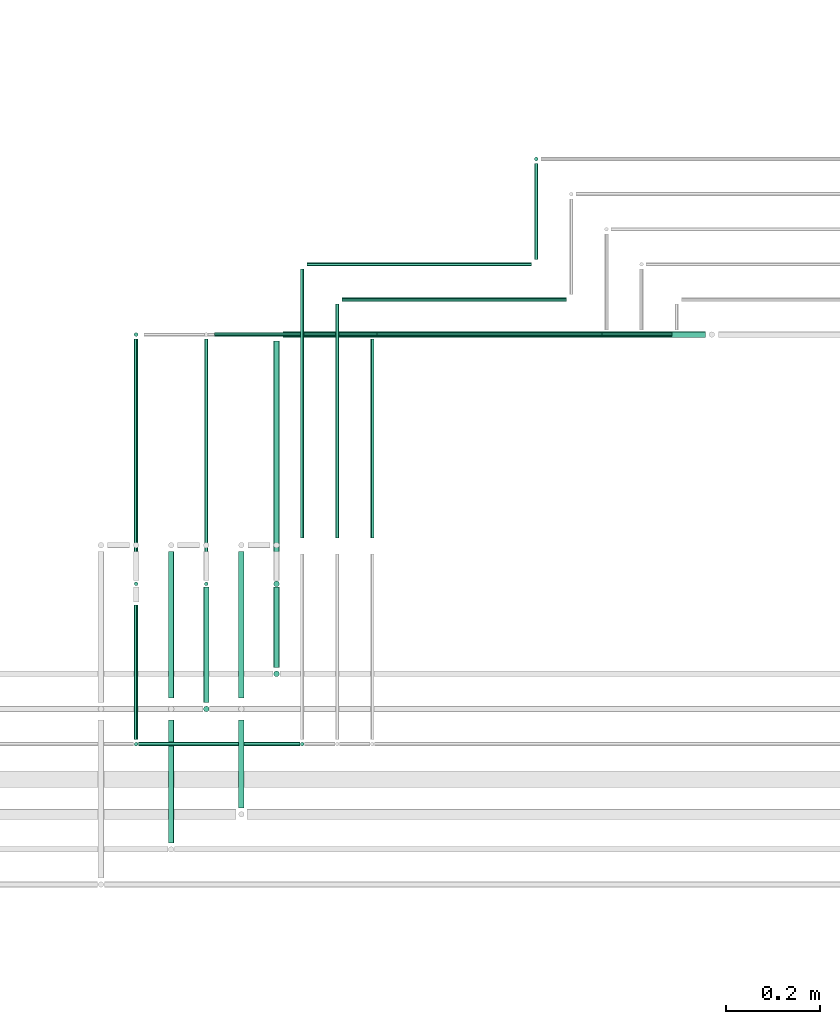
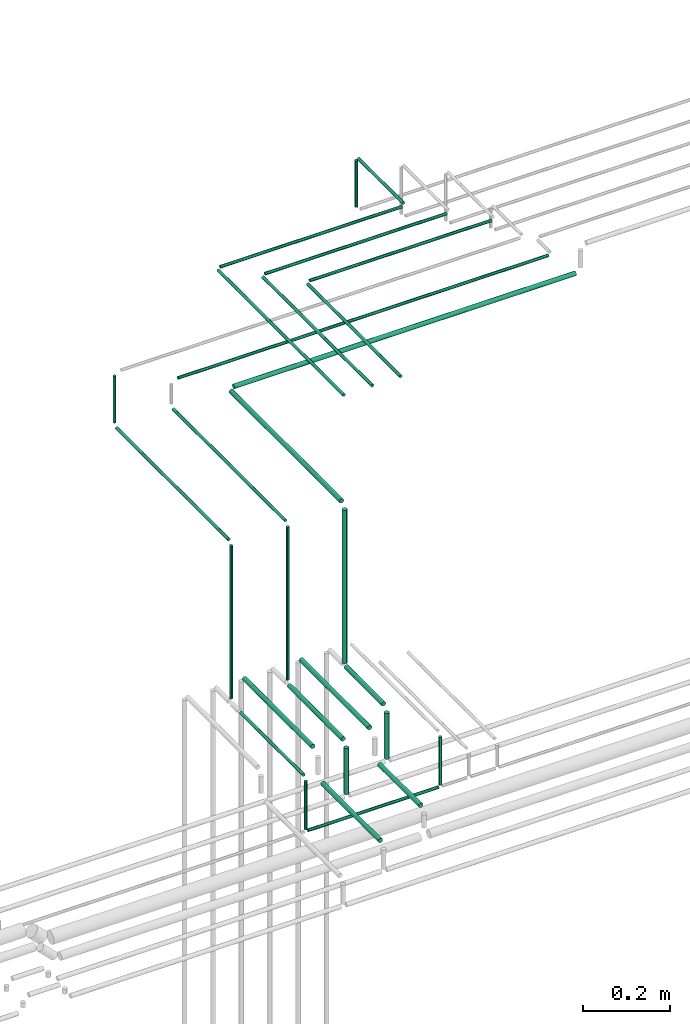
# One storey, part 167 of 331: 29 flow segments.
"""IFC2X3 building model written with IfcOpenShell, lengths in millimetres."""

import ifcopenshell
import ifcopenshell.guid

model = None  # the IFC model being written
_history = None  # IfcOwnerHistory: only IFC2X3 demands one
_inside = {}  # id of a spatial element -> (the spatial element, [elements in it])
_under = {}  # id of a project, library or spatial element -> (it, [spatial elements below it])
_declared = {}  # id of a project -> (the project, [libraries it declares])
_typed = {}  # id of a type object -> (the type object, [elements of that type])
_made_of = {}  # id of a material, layer set ... -> (it, [elements and type objects made of it])


def new_model(schema):
    """Start an empty IFC model of exactly this schema.

    Asked for "IFC4X3", IfcOpenShell would pick the latest addendum, in which some entities
    have other attributes; the version numbers below select the first issue.
    IFC2X3 requires an IfcOwnerHistory on every rooted entity: one is made here for all.
    """
    global model, _history
    if schema == "IFC4X3":
        model = ifcopenshell.file(schema_version=(4, 3, 0, 0))
    else:
        model = ifcopenshell.file(schema=schema)
    _inside.clear()
    _under.clear()
    _declared.clear()
    _typed.clear()
    _made_of.clear()
    _history = None
    if model.schema == "IFC2X3":
        org = make("IfcOrganization", Name="unknown")
        user = make(
            "IfcPersonAndOrganization",
            ThePerson=make("IfcPerson", FamilyName="unknown"),
            TheOrganization=org,
        )
        app = make(
            "IfcApplication",
            ApplicationDeveloper=org,
            Version="unknown",
            ApplicationFullName="unknown",
            ApplicationIdentifier="unknown",
        )
        _history = make(
            "IfcOwnerHistory",
            OwningUser=user,
            OwningApplication=app,
            ChangeAction="ADDED",
            CreationDate=0,
        )
    return model


def make(cls, **values):
    """One entity of the class cls with the attributes given. An attribute that is None is left unset."""
    return model.create_entity(
        cls, **{name: value for name, value in values.items() if value is not None}
    )


def entity(cls, *values):
    """Any entity or typed value of the class cls, its attributes in the order of the schema. None: left unset."""
    e = model.create_entity(cls)
    for i, value in enumerate(values):
        if value is not None:
            e[i] = value
    return e


def rooted(cls, **values):
    """An entity with a GlobalId (a new one), such as an element, a storey or a relation."""
    return make(cls, GlobalId=ifcopenshell.guid.new(), OwnerHistory=_history, **values)


def si_unit(unit_type, name, prefix=None):
    """IfcSIUnit, for example si_unit("LENGTHUNIT", "METRE", prefix="MILLI")."""
    return make("IfcSIUnit", UnitType=unit_type, Prefix=prefix, Name=name)


def converted_unit(unit_type, name, factor, base, dimensions=None, offset=None):
    """IfcConversionBasedUnit, such as the inch: factor (a typed value) times the base unit."""
    return make(
        "IfcConversionBasedUnit"
        if offset is None
        else "IfcConversionBasedUnitWithOffset",
        ConversionOffset=offset,
        Dimensions=None
        if dimensions is None
        else entity("IfcDimensionalExponents", *dimensions),
        UnitType=unit_type,
        Name=name,
        ConversionFactor=make(
            "IfcMeasureWithUnit", ValueComponent=factor, UnitComponent=base
        ),
    )


def derived_unit(unit_type, elements):
    """IfcDerivedUnit: a product of units, each with its exponent."""
    return make(
        "IfcDerivedUnit",
        Elements=[
            make("IfcDerivedUnitElement", Unit=unit, Exponent=power)
            for unit, power in elements
        ],
        UnitType=unit_type,
    )


def assignment(units):
    """IfcUnitAssignment: the units of a project."""
    return None if units is None else make("IfcUnitAssignment", Units=units)


def point(xyz):
    """IfcCartesianPoint."""
    return None if xyz is None else make("IfcCartesianPoint", Coordinates=xyz)


def direction(xyz):
    """IfcDirection."""
    return None if xyz is None else make("IfcDirection", DirectionRatios=xyz)


def frame(location, z_axis=None, x_axis=None):
    """IfcAxis2Placement3D, a coordinate frame: its origin and axes. An axis left out is left unset."""
    return make(
        "IfcAxis2Placement3D",
        Location=point(location),
        Axis=direction(z_axis),
        RefDirection=direction(x_axis),
    )


def frame_2d(location, x_axis=None):
    """IfcAxis2Placement2D, a coordinate frame in the plane: its origin and x axis."""
    return make(
        "IfcAxis2Placement2D", Location=point(location), RefDirection=direction(x_axis)
    )


def origin():
    """The frame at (0, 0, 0) with its axes left unset."""
    return frame((0.0, 0.0, 0.0))


def origin_2d_with_axis():
    """The frame at (0, 0) in the plane with the x axis (1, 0) written out."""
    return frame_2d((0.0, 0.0), x_axis=(1.0, 0.0))


def place(relative_to, where):
    """IfcLocalPlacement: puts the frame where relative to a parent placement (None: the world)."""
    return make(
        "IfcLocalPlacement", PlacementRelTo=relative_to, RelativePlacement=where
    )


def context(
    kind, dimensions, precision=None, world=None, true_north=None, identifier=None
):
    """IfcGeometricRepresentationContext, for example the 3D "Model" context."""
    return make(
        "IfcGeometricRepresentationContext",
        ContextIdentifier=identifier,
        ContextType=kind,
        CoordinateSpaceDimension=dimensions,
        Precision=precision,
        WorldCoordinateSystem=world,
        TrueNorth=true_north,
    )


def subcontext(parent, identifier, kind, view, scale=None):
    """IfcGeometricRepresentationSubContext, for example "Body" below "Model"."""
    return make(
        "IfcGeometricRepresentationSubContext",
        ContextIdentifier=identifier,
        ContextType=kind,
        ParentContext=parent,
        TargetScale=scale,
        TargetView=view,
    )


def project(units=None, contexts=None):
    """IfcProject with its units and contexts."""
    return rooted(
        "IfcProject",
        Name="project",
        RepresentationContexts=contexts,
        UnitsInContext=assignment(units),
    )


def spatial(cls, under=None, at=None, **own):
    """A site, building, storey or space (cls), placed at a placement, below another one or the project."""
    s = rooted(cls, ObjectPlacement=at, **own)
    if under is not None:
        _under.setdefault(under.id(), (under, []))[1].append(s)
    return s


def profile(cls, at=None, kind="AREA", **sizes):
    """A parametric profile (cls). Its sizes go by their IFC names, for example OverallWidth=200.0."""
    return make(cls, ProfileType=kind, Position=at, **sizes)


def circle(**sizes):
    """IfcCircleProfileDef."""
    return profile("IfcCircleProfileDef", **sizes)


def extrude(swept, where, along, depth):
    """IfcExtrudedAreaSolid: the profile swept, set in the frame where, extruded along a direction by depth."""
    return make(
        "IfcExtrudedAreaSolid",
        SweptArea=swept,
        Position=where,
        ExtrudedDirection=direction(along),
        Depth=depth,
    )


def shape(context_of_items, identifier, shape_type, items):
    """IfcShapeRepresentation: the items that make up one representation, for example the "Body"."""
    return make(
        "IfcShapeRepresentation",
        ContextOfItems=context_of_items,
        RepresentationIdentifier=identifier,
        RepresentationType=shape_type,
        Items=items,
    )


def made_of(thing, what):
    """Note that an element or type object is made of a material, layer set ...; save() writes the relation."""
    if what is not None:
        _made_of.setdefault(what.id(), (what, []))[1].append(thing)
    return thing


def type_object(cls, material=None, **own):
    """A type object (cls), such as IfcWallType, which elements share."""
    return made_of(rooted(cls, **own), material)


def element(
    cls,
    number,
    at=None,
    inside=None,
    cuts=None,
    type_object=None,
    material=None,
    context=None,
    identifier="Body",
    shape_type=None,
    held_by="IfcProductDefinitionShape",
    body=None,
    shapes=None,
    **own,
):
    """One element of the class cls, such as IfcWall. Its Tag is "e" and its number.

    at: its placement. inside: the storey or other place that contains it. cuts: it is an
    opening in that element (IfcRelVoidsElement). A single representation is given by context,
    identifier, shape_type and body (its items); several are given by shapes. held_by: the class
    of the entity that holds the representations. save() writes the other relations.
    """
    e = rooted(cls, Tag="e%d" % number, ObjectPlacement=at, **own)
    if body is not None:
        shapes = [shape(context, identifier, shape_type, body)]
    if shapes is not None:
        e.Representation = make(held_by, Representations=shapes)
    if inside is not None:
        _inside.setdefault(inside.id(), (inside, []))[1].append(e)
    if cuts is not None:
        rooted(
            "IfcRelVoidsElement", RelatingBuildingElement=cuts, RelatedOpeningElement=e
        )
    if type_object is not None:
        _typed.setdefault(type_object.id(), (type_object, []))[1].append(e)
    return made_of(e, material)


def aggregate(whole, parts):
    """IfcRelAggregates: a whole, such as a stair, and the parts it consists of."""
    return rooted("IfcRelAggregates", RelatingObject=whole, RelatedObjects=parts)


def save(model, path):
    """Write the relations noted so far, then the file.

    IfcRelAggregates (storeys below a building ...), IfcRelContainedInSpatialStructure (elements
    in a storey), IfcRelDefinesByType, IfcRelAssociatesMaterial and IfcRelDeclares: one each for
    every whole, place, type object, material and project.
    """
    for whole, parts in _under.values():
        aggregate(whole, parts)
    for where, things in _inside.values():
        rooted(
            "IfcRelContainedInSpatialStructure",
            RelatedElements=things,
            RelatingStructure=where,
        )
    for kind, things in _typed.values():
        rooted("IfcRelDefinesByType", RelatedObjects=things, RelatingType=kind)
    for what, things in _made_of.values():
        rooted("IfcRelAssociatesMaterial", RelatedObjects=things, RelatingMaterial=what)
    for by, libraries in _declared.values():
        rooted("IfcRelDeclares", RelatingContext=by, RelatedDefinitions=libraries)
    model.write(path)


model = new_model("IFC2X3")

# Units and contexts
model_context = context("Model", 3, precision=0.01, world=origin(), true_north=direction((6.12303176911189e-17, 1.0)))
body_context = subcontext(model_context, "Body", "Model", "MODEL_VIEW")
ifc_project = project(units=[si_unit("LENGTHUNIT", "METRE", prefix="MILLI"), si_unit("AREAUNIT", "SQUARE_METRE"), si_unit("VOLUMEUNIT", "CUBIC_METRE"), converted_unit("PLANEANGLEUNIT", "DEGREE", entity("IfcRatioMeasure", 0.0174532925199433), si_unit("PLANEANGLEUNIT", "RADIAN"), dimensions=[0, 0, 0, 0, 0, 0, 0]), si_unit("MASSUNIT", "GRAM", prefix="KILO"), derived_unit("MASSDENSITYUNIT", [(si_unit("MASSUNIT", "GRAM", prefix="KILO"), 1), (si_unit("LENGTHUNIT", "METRE"), -3)]), derived_unit("MOMENTOFINERTIAUNIT", [(si_unit("LENGTHUNIT", "METRE"), 4)]), si_unit("TIMEUNIT", "SECOND"), si_unit("FREQUENCYUNIT", "HERTZ"), si_unit("THERMODYNAMICTEMPERATUREUNIT", "DEGREE_CELSIUS"), derived_unit("THERMALTRANSMITTANCEUNIT", [(si_unit("MASSUNIT", "GRAM", prefix="KILO"), 1), (si_unit("THERMODYNAMICTEMPERATUREUNIT", "KELVIN"), -1), (si_unit("TIMEUNIT", "SECOND"), -3)]), derived_unit("VOLUMETRICFLOWRATEUNIT", [(si_unit("LENGTHUNIT", "METRE"), 3), (si_unit("TIMEUNIT", "SECOND"), -1)]), derived_unit("MASSFLOWRATEUNIT", [(si_unit("MASSUNIT", "GRAM", prefix="KILO"), 1), (si_unit("TIMEUNIT", "SECOND"), -1)]), derived_unit("ROTATIONALFREQUENCYUNIT", [(si_unit("TIMEUNIT", "SECOND"), -1)]), si_unit("ELECTRICCURRENTUNIT", "AMPERE"), si_unit("ELECTRICVOLTAGEUNIT", "VOLT"), si_unit("POWERUNIT", "WATT"), si_unit("FORCEUNIT", "NEWTON", prefix="KILO"), si_unit("ILLUMINANCEUNIT", "LUX"), si_unit("LUMINOUSFLUXUNIT", "LUMEN"), si_unit("LUMINOUSINTENSITYUNIT", "CANDELA"), derived_unit("USERDEFINED", [(si_unit("MASSUNIT", "GRAM", prefix="KILO"), -1), (si_unit("LENGTHUNIT", "METRE"), -2), (si_unit("TIMEUNIT", "SECOND"), 3), (si_unit("LUMINOUSFLUXUNIT", "LUMEN"), 1)]), derived_unit("LINEARVELOCITYUNIT", [(si_unit("LENGTHUNIT", "METRE"), 1), (si_unit("TIMEUNIT", "SECOND"), -1)]), si_unit("PRESSUREUNIT", "PASCAL"), derived_unit("USERDEFINED", [(si_unit("LENGTHUNIT", "METRE"), -2), (si_unit("MASSUNIT", "GRAM", prefix="KILO"), 1), (si_unit("TIMEUNIT", "SECOND"), -2)]), derived_unit("LINEARFORCEUNIT", [(si_unit("MASSUNIT", "GRAM", prefix="KILO"), 1), (si_unit("LENGTHUNIT", "METRE"), 1), (si_unit("TIMEUNIT", "SECOND"), -2), (si_unit("LENGTHUNIT", "METRE"), -1)]), derived_unit("PLANARFORCEUNIT", [(si_unit("MASSUNIT", "GRAM", prefix="KILO"), 1), (si_unit("LENGTHUNIT", "METRE"), 1), (si_unit("TIMEUNIT", "SECOND"), -2), (si_unit("LENGTHUNIT", "METRE"), -2)])], contexts=[model_context])

# Site, building, storey
site_placement = place(None, frame((0.0, -0.00077364408347762, 0.0)))
site = spatial("IfcSite", under=ifc_project, at=site_placement, CompositionType="ELEMENT")
building_placement = place(site_placement, origin())
building = spatial("IfcBuilding", under=site, at=building_placement, CompositionType="ELEMENT")
storey_placement = place(building_placement, origin())
storey = spatial("IfcBuildingStorey", under=building, at=storey_placement, CompositionType="ELEMENT", Elevation=0.0)

# Flow segments
pipe_segment_type = type_object("IfcPipeSegmentType", PredefinedType="NOTDEFINED")
flow_segment_1_placement = place(building_placement, frame((37616.6646214607, 16236.7040533214, 6838.0)))
element("IfcFlowSegment", 1, at=flow_segment_1_placement, inside=storey, type_object=pipe_segment_type, context=body_context, shape_type="SweptSolid", body=[
    extrude(circle(Radius=4.0, at=origin_2d_with_axis()), frame((5.59527223591499, 5.59527223591499, 0.0), z_axis=(0.0, 0.0, 1.0), x_axis=(-1.0, 0.0, 0.0)), (0.0, 0.0, 1.0), 426.999999999964),
])
flow_segment_2_placement = place(building_placement, frame((37616.6646214607, 15909.9846702029, 6819.40472776411)))
element("IfcFlowSegment", 2, at=flow_segment_2_placement, inside=storey, type_object=pipe_segment_type, context=body_context, shape_type="SweptSolid", body=[
    extrude(circle(Radius=4.0, at=frame_2d((0.0, -1.08286712929839e-12), x_axis=(1.0, 0.0))), frame((5.59527223591499, 0.0, 5.59527223591499), z_axis=(0.0, 1.0, 0.0), x_axis=(1.0, 0.0, 0.0)), (0.0, 0.0, 1.0), 287.604282131364),
])
flow_segment_3_placement = place(building_placement, frame((37616.6646214606, 16252.2993255573, 7269.40472776408)))
element("IfcFlowSegment", 3, at=flow_segment_3_placement, inside=storey, type_object=pipe_segment_type, context=body_context, shape_type="SweptSolid", body=[
    extrude(circle(Radius=4.0, at=frame_2d((0.0, -1.08286712929839e-12), x_axis=(1.0, 0.0))), frame((5.59527223591499, 0.0, 5.59527223591716), z_axis=(0.0, 1.0, 0.0), x_axis=(-1.0, 0.0, 0.0)), (0.0, 0.0, 1.0), 512.685344645421),
])
flow_segment_4_placement = place(storey_placement, frame((37689.6646214607, 15997.9846702029, 6817.40472776408)))
element("IfcFlowSegment", 4, at=flow_segment_4_placement, inside=storey, type_object=pipe_segment_type, context=body_context, shape_type="SweptSolid", body=[
    extrude(circle(Radius=6.0, at=frame_2d((0.0, -1.08286712929839e-12), x_axis=(1.0, 0.0))), frame((7.5952722359232, 0.0, 7.59527223591454), z_axis=(0.0, 1.0, 0.0), x_axis=(1.0, 0.0, 0.0)), (0.0, 0.0, 1.0), 313.00000000002),
])
flow_segment_5_placement = place(storey_placement, frame((37766.6646214607, 16236.7040533214, 6838.0)))
element("IfcFlowSegment", 5, at=flow_segment_5_placement, inside=storey, type_object=pipe_segment_type, context=body_context, shape_type="SweptSolid", body=[
    extrude(circle(Radius=4.0, at=origin_2d_with_axis()), frame((5.59527223591499, 5.59527223591499, 0.0), z_axis=(0.0, 0.0, 1.0), x_axis=(-1.0, 0.0, 0.0)), (0.0, 0.0, 1.0), 426.999999999972),
])
flow_segment_6_placement = place(storey_placement, frame((37764.6646214607, 15988.9846702029, 6817.40472776411)))
element("IfcFlowSegment", 6, at=flow_segment_6_placement, inside=storey, type_object=pipe_segment_type, context=body_context, shape_type="SweptSolid", body=[
    extrude(circle(Radius=6.0, at=frame_2d((0.0, -1.08286712929839e-12), x_axis=(1.0, 0.0))), frame((7.59527223591454, 0.0, 7.59527223591454), z_axis=(0.0, 1.0, 0.0), x_axis=(1.0, 0.0, 0.0)), (0.0, 0.0, 1.0), 246.314655354431),
])
flow_segment_7_placement = place(storey_placement, frame((37766.6646214606, 16252.2993255574, 7269.40472776407)))
element("IfcFlowSegment", 7, at=flow_segment_7_placement, inside=storey, type_object=pipe_segment_type, context=body_context, shape_type="SweptSolid", body=[
    extrude(circle(Radius=4.0, at=frame_2d((0.0, -1.08286712929839e-12), x_axis=(1.0, 0.0))), frame((5.59527223591499, 0.0, 5.59527223591716), z_axis=(0.0, 1.0, 0.0), x_axis=(-1.0, 0.0, 0.0)), (0.0, 0.0, 1.0), 512.685344645418),
])
flow_segment_8_placement = place(storey_placement, frame((37839.6646214607, 15997.9846702029, 6817.40472776408)))
element("IfcFlowSegment", 8, at=flow_segment_8_placement, inside=storey, type_object=pipe_segment_type, context=body_context, shape_type="SweptSolid", body=[
    extrude(circle(Radius=6.0, at=frame_2d((0.0, -1.08286712929839e-12), x_axis=(1.0, 0.0))), frame((7.5952722359232, 0.0, 7.59527223591454), z_axis=(0.0, 1.0, 0.0), x_axis=(1.0, 0.0, 0.0)), (0.0, 0.0, 1.0), 313.00000000002),
])
flow_segment_9_placement = place(storey_placement, frame((37914.6646214607, 16234.7040533214, 6832.0)))
element("IfcFlowSegment", 9, at=flow_segment_9_placement, inside=storey, type_object=pipe_segment_type, context=body_context, shape_type="SweptSolid", body=[
    extrude(circle(Radius=6.0, at=origin_2d_with_axis()), frame((7.59527223591454, 7.5952722359167, 0.0), z_axis=(0.0, 0.0, 1.0), x_axis=(-1.0, 0.0, 0.0)), (0.0, 0.0, 1.0), 428.999999999974),
])
flow_segment_10_placement = place(storey_placement, frame((37914.6646214607, 16063.9846702029, 6817.40472776411)))
element("IfcFlowSegment", 10, at=flow_segment_10_placement, inside=storey, type_object=pipe_segment_type, context=body_context, shape_type="SweptSolid", body=[
    extrude(circle(Radius=6.0, at=origin_2d_with_axis()), frame((7.59527223591454, 0.0, 7.59527223591562), z_axis=(0.0, 1.0, 0.0), x_axis=(1.0, 0.0, 0.0)), (0.0, 0.0, 1.0), 171.314655354433),
])
flow_segment_11_placement = place(storey_placement, frame((37914.6646214606, 16256.2993255574, 7267.40472776408)))
element("IfcFlowSegment", 11, at=flow_segment_11_placement, inside=storey, type_object=pipe_segment_type, context=body_context, shape_type="SweptSolid", body=[
    extrude(circle(Radius=6.0, at=frame_2d((0.0, -1.08286712929839e-12), x_axis=(1.0, 0.0))), frame((7.59527223591454, 0.0, 7.5952722359167), z_axis=(0.0, 1.0, 0.0), x_axis=(-1.0, 0.0, 0.0)), (0.0, 0.0, 1.0), 504.685344645414),
])
flow_segment_12_placement = place(storey_placement, frame((37971.440385921, 16340.2503647959, 7494.40472776408)))
element("IfcFlowSegment", 12, at=flow_segment_12_placement, inside=storey, type_object=pipe_segment_type, context=body_context, shape_type="SweptSolid", body=[
    extrude(circle(Radius=4.0, at=frame_2d((8.66293703438714e-12, 0.0), x_axis=(1.0, 0.0))), frame((5.59527223592365, 0.0, 5.59527223591607), z_axis=(0.0, 1.0, 0.0), x_axis=(-1.0, 0.0, 0.0)), (0.0, 0.0, 1.0), 574.734305406875),
])
flow_segment_13_placement = place(storey_placement, frame((38046.440385921, 16340.2503647959, 7494.40472776408)))
element("IfcFlowSegment", 13, at=flow_segment_13_placement, inside=storey, type_object=pipe_segment_type, context=body_context, shape_type="SweptSolid", body=[
    extrude(circle(Radius=4.0, at=frame_2d((8.66293703438714e-12, 0.0), x_axis=(1.0, 0.0))), frame((5.59527223592365, 0.0, 5.59527223591607), z_axis=(0.0, 1.0, 0.0), x_axis=(-1.0, 0.0, 0.0)), (0.0, 0.0, 1.0), 499.734305406866),
])
flow_segment_14_placement = place(building_placement, frame((38121.4403859209, 16340.2503647959, 7494.40472776408)))
element("IfcFlowSegment", 14, at=flow_segment_14_placement, inside=storey, type_object=pipe_segment_type, context=body_context, shape_type="SweptSolid", body=[
    extrude(circle(Radius=4.0, at=frame_2d((8.66293703438714e-12, -1.08286712929839e-12), x_axis=(1.0, 0.0))), frame((5.59527223592365, 0.0, 5.59527223591716), z_axis=(0.0, 1.0, 0.0), x_axis=(-1.0, 0.0, 0.0)), (0.0, 0.0, 1.0), 424.734305406859),
])
flow_segment_15_placement = place(building_placement, frame((37616.6646214607, 15894.389397967, 6680.0)))
element("IfcFlowSegment", 15, at=flow_segment_15_placement, inside=storey, type_object=pipe_segment_type, context=body_context, shape_type="SweptSolid", body=[
    extrude(circle(Radius=4.0, at=origin_2d_with_axis()), frame((5.59527223591499, 5.59527223591499, 0.0), z_axis=(0.0, 0.0, 1.0), x_axis=(-1.0, 0.0, 0.0)), (0.0, 0.0, 1.0), 135.000000000009),
])
flow_segment_16_placement = place(storey_placement, frame((37689.6646214607, 15688.9846702029, 6742.40472776409)))
element("IfcFlowSegment", 16, at=flow_segment_16_placement, inside=storey, type_object=pipe_segment_type, context=body_context, shape_type="SweptSolid", body=[
    extrude(circle(Radius=6.0, at=frame_2d((0.0, -1.08286712929839e-12), x_axis=(1.0, 0.0))), frame((7.59527223591454, 0.0, 7.59527223591454), z_axis=(0.0, 1.0, 0.0), x_axis=(1.0, 0.0, 0.0)), (0.0, 0.0, 1.0), 262.999999999968),
])
flow_segment_17_placement = place(storey_placement, frame((37764.6646214607, 15967.389397967, 6682.0)))
element("IfcFlowSegment", 17, at=flow_segment_17_placement, inside=storey, type_object=pipe_segment_type, context=body_context, shape_type="SweptSolid", body=[
    extrude(circle(Radius=6.0, at=origin_2d_with_axis()), frame((7.59527223591454, 7.5952722359167, 0.0), z_axis=(0.0, 0.0, 1.0), x_axis=(-1.0, 0.0, 0.0)), (0.0, 0.0, 1.0), 129.00000000002),
])
flow_segment_18_placement = place(storey_placement, frame((37839.6646214607, 15763.9846702029, 6742.40472776409)))
element("IfcFlowSegment", 18, at=flow_segment_18_placement, inside=storey, type_object=pipe_segment_type, context=body_context, shape_type="SweptSolid", body=[
    extrude(circle(Radius=6.0, at=frame_2d((0.0, -1.08286712929839e-12), x_axis=(1.0, 0.0))), frame((7.59527223591454, 0.0, 7.59527223591454), z_axis=(0.0, 1.0, 0.0), x_axis=(1.0, 0.0, 0.0)), (0.0, 0.0, 1.0), 187.999999999957),
])
flow_segment_19_placement = place(storey_placement, frame((37914.6646214607, 16042.389397967, 6682.0)))
element("IfcFlowSegment", 19, at=flow_segment_19_placement, inside=storey, type_object=pipe_segment_type, context=body_context, shape_type="SweptSolid", body=[
    extrude(circle(Radius=6.0, at=origin_2d_with_axis()), frame((7.59527223591454, 7.5952722359167, 0.0), z_axis=(0.0, 0.0, 1.0), x_axis=(-1.0, 0.0, 0.0)), (0.0, 0.0, 1.0), 129.000000000019),
])
flow_segment_20_placement = place(storey_placement, frame((37971.440385921, 15894.389397967, 6680.0)))
element("IfcFlowSegment", 20, at=flow_segment_20_placement, inside=storey, type_object=pipe_segment_type, context=body_context, shape_type="SweptSolid", body=[
    extrude(circle(Radius=4.0, at=origin_2d_with_axis()), frame((5.59527223591499, 5.59527223591499, 0.0), z_axis=(0.0, 0.0, 1.0), x_axis=(-1.0, 0.0, 0.0)), (0.0, 0.0, 1.0), 134.999999999983),
])
flow_segment_21_placement = place(storey_placement, frame((37627.2598936966, 15894.389397967, 6669.4047277641)))
element("IfcFlowSegment", 21, at=flow_segment_21_placement, inside=storey, type_object=pipe_segment_type, context=body_context, shape_type="SweptSolid", body=[
    extrude(circle(Radius=4.0, at=frame_2d((0.0, -1.08286712929839e-12), x_axis=(1.0, 0.0))), frame((0.0, 5.59527223591282, 5.59527223591499), z_axis=(1.0, 0.0, 0.0), x_axis=(0.0, -1.0, 0.0)), (0.0, 0.0, 1.0), 344.7757644603),
])
flow_segment_22_placement = place(building_placement, frame((37616.6646214606, 16769.3893979669, 7285.0)))
element("IfcFlowSegment", 22, at=flow_segment_22_placement, inside=storey, type_object=pipe_segment_type, context=body_context, shape_type="SweptSolid", body=[
    extrude(circle(Radius=4.0, at=origin_2d_with_axis()), frame((5.59527223591499, 5.59527223591499, 0.0)), (0.0, 0.0, 1.0), 130.000000000004),
])
flow_segment_23_placement = place(storey_placement, frame((37789.2598936966, 16769.3893979668, 7344.40472776408)))
element("IfcFlowSegment", 23, at=flow_segment_23_placement, inside=storey, type_object=pipe_segment_type, context=body_context, shape_type="SweptSolid", body=[
    extrude(circle(Radius=4.0, at=frame_2d((-4.33146851719357e-12, 1.08286712929839e-12), x_axis=(1.0, 0.0))), frame((0.0, 5.59527223591932, 5.59527223591932), z_axis=(1.0, 0.0, 0.0), x_axis=(0.0, 1.0, 0.0)), (0.0, 0.0, 1.0), 977.882851877655),
])
flow_segment_24_placement = place(storey_placement, frame((38471.5474733383, 16934.9846702027, 7494.4047277641)))
element("IfcFlowSegment", 24, at=flow_segment_24_placement, inside=storey, type_object=pipe_segment_type, context=body_context, shape_type="SweptSolid", body=[
    extrude(circle(Radius=4.0, at=frame_2d((1.29944055515807e-11, 0.0), x_axis=(1.0, 0.0))), frame((5.59527223592365, 0.0, 5.59527223591607), z_axis=(0.0, 1.0, 0.0), x_axis=(-1.0, 0.0, 0.0)), (0.0, 0.0, 1.0), 205.000000000031),
])
flow_segment_25_placement = place(storey_placement, frame((38137.0356581569, 16769.3893979668, 7494.40472776408)))
element("IfcFlowSegment", 25, at=flow_segment_25_placement, inside=storey, type_object=pipe_segment_type, context=body_context, shape_type="SweptSolid", body=[
    extrude(circle(Radius=4.0, at=frame_2d((-8.66293703438714e-12, 1.08286712929839e-12), x_axis=(1.0, 0.0))), frame((0.0, 5.59527223592365, 5.59527223591716), z_axis=(1.0, 0.0, 0.0), x_axis=(0.0, 1.0, 0.0)), (0.0, 0.0, 1.0), 480.107087417351),
])
flow_segment_26_placement = place(storey_placement, frame((38062.0356581569, 16844.3893979668, 7494.40472776408)))
element("IfcFlowSegment", 26, at=flow_segment_26_placement, inside=storey, type_object=pipe_segment_type, context=body_context, shape_type="SweptSolid", body=[
    extrude(circle(Radius=4.0, at=frame_2d((-1.29944055515807e-11, 1.08286712929839e-12), x_axis=(1.0, 0.0))), frame((0.0, 5.59527223592799, 5.59527223591716), z_axis=(1.0, 0.0, 0.0), x_axis=(0.0, 1.0, 0.0)), (0.0, 0.0, 1.0), 480.107087417342),
])
flow_segment_27_placement = place(storey_placement, frame((37987.0356581569, 16919.3893979668, 7494.40472776408)))
element("IfcFlowSegment", 27, at=flow_segment_27_placement, inside=storey, type_object=pipe_segment_type, context=body_context, shape_type="SweptSolid", body=[
    extrude(circle(Radius=4.0, at=origin_2d_with_axis()), frame((0.0, 5.59527223595181, 5.59527223591607), z_axis=(1.0, 0.0, 0.0), x_axis=(0.0, -1.0, 0.0)), (0.0, 0.0, 1.0), 480.107087417347),
])
flow_segment_28_placement = place(storey_placement, frame((37936.2598936966, 16767.3893979669, 7267.40472776408)))
element("IfcFlowSegment", 28, at=flow_segment_28_placement, inside=storey, type_object=pipe_segment_type, context=body_context, shape_type="SweptSolid", body=[
    extrude(circle(Radius=6.0, at=frame_2d((-2.16573425859679e-12, -1.08286712929839e-12), x_axis=(1.0, 0.0))), frame((0.0, 7.59527223591454, 7.59527223591454), z_axis=(1.0, 0.0, 0.0), x_axis=(0.0, -1.0, 0.0)), (0.0, 0.0, 1.0), 902.000000000029),
])
flow_segment_29_placement = place(storey_placement, frame((38471.5474733383, 17144.3893979669, 7360.0)))
element("IfcFlowSegment", 29, at=flow_segment_29_placement, inside=storey, type_object=pipe_segment_type, context=body_context, shape_type="SweptSolid", body=[
    extrude(circle(Radius=4.0, at=origin_2d_with_axis()), frame((5.59527223591499, 5.59527223591499, 0.0), z_axis=(0.0, 0.0, 1.0), x_axis=(-1.0, 0.0, 0.0)), (0.0, 0.0, 1.0), 130.000000000025),
])

save(model, "model.ifc")
